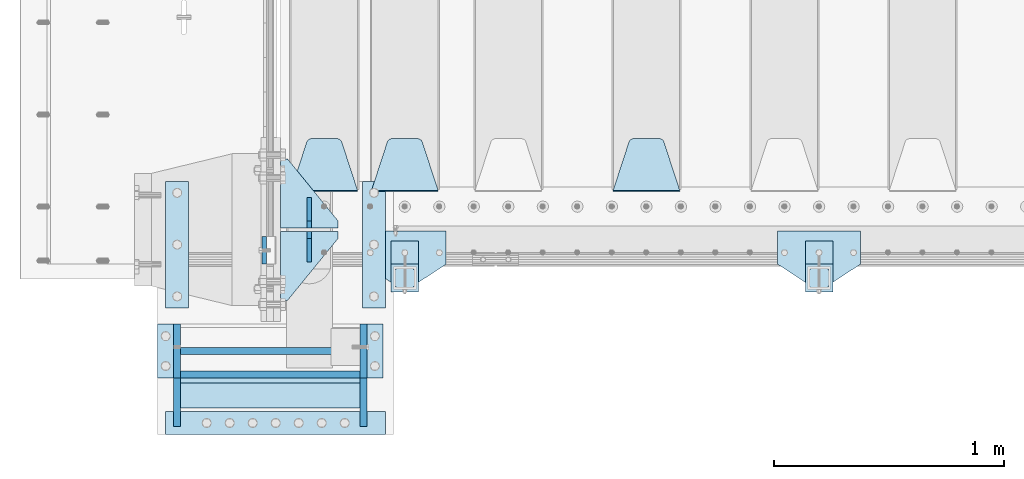
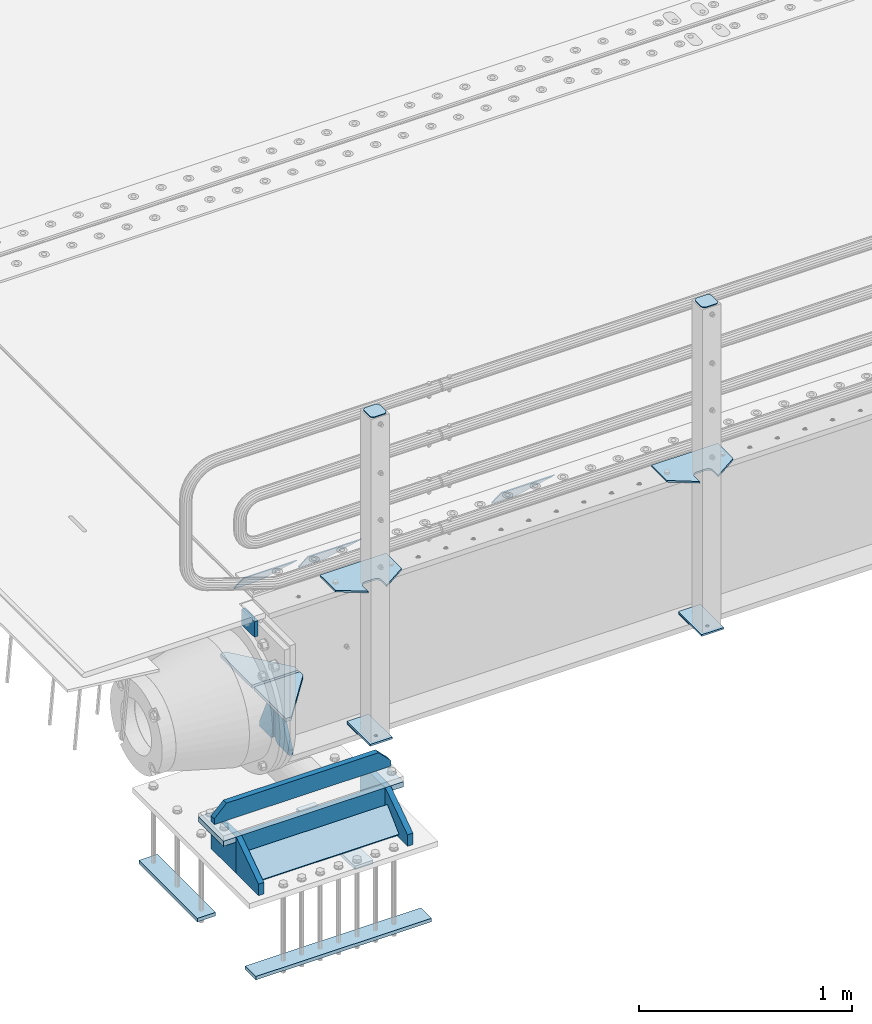
# One storey, part 174 of 219: 28 plates.
"""IFC2X3 building model written with IfcOpenShell, lengths in millimetres."""

from ifc_helpers import new_model, si_unit, frame, origin_with_axes, place, context, subcontext, project, spatial, faceted_brep, material, type_object, element, save


model = new_model("IFC2X3")

# Units and contexts
model_context = context("Model", 3, precision=1e-05, world=origin_with_axes())
body_context = subcontext(model_context, "Body", "Model", "MODEL_VIEW")
ifc_project = project(units=[si_unit("LENGTHUNIT", "METRE", prefix="MILLI"), si_unit("AREAUNIT", "SQUARE_METRE"), si_unit("VOLUMEUNIT", "CUBIC_METRE"), si_unit("MASSUNIT", "GRAM", prefix="KILO"), si_unit("TIMEUNIT", "SECOND"), si_unit("PLANEANGLEUNIT", "RADIAN"), si_unit("SOLIDANGLEUNIT", "STERADIAN"), si_unit("THERMODYNAMICTEMPERATUREUNIT", "DEGREE_CELSIUS"), si_unit("LUMINOUSINTENSITYUNIT", "LUMEN")], contexts=[model_context])

# Site, building, storey
site_placement = place(None, origin_with_axes())
site = spatial("IfcSite", under=ifc_project, at=site_placement, CompositionType="ELEMENT")
building_placement = place(site_placement, origin_with_axes())
building = spatial("IfcBuilding", under=site, at=building_placement, Name="Standard", CompositionType="ELEMENT")
storey_placement = place(building_placement, origin_with_axes())
storey = spatial("IfcBuildingStorey", under=building, at=storey_placement, Name="Undefined", CompositionType="ELEMENT", Elevation=0.0)

# Plates
ifc_material_1 = material(Name="STEEL/S355N")
plate_type_1 = type_object("IfcPlateType", PredefinedType="NOTDEFINED")
plate_1_placement = place(storey_placement, frame((-60.0000000001136, 23970.0004459814, -106.000105640918), z_axis=(0.0, -0.999999999987744, -4.95099999993769e-06), x_axis=(0.0, -4.95099997756316e-06, 0.999999999987744)))
element("IfcPlate", 1, at=plate_1_placement, inside=storey, type_object=plate_type_1, material=ifc_material_1, context=body_context, shape_type="Brep", body=[
    faceted_brep([(0.0, -10.0, 0.0), (4.30816271546064e-10, -10.0, 120.000000000004), (4.30816271546064e-10, 10.0, 120.000000000004), (0.0, 10.0, 0.0), (89.9999999999979, -10.0, 120.000000000004), (89.9999999999979, 10.0, 120.000000000004), (90.0, -10.0, 1.09139364212751e-11), (90.0, 10.0, 1.09139364212751e-11)], [[[0, 1, 2, 3]], [[1, 4, 5, 2]], [[4, 6, 7, 5]], [[6, 0, 3, 7]], [[5, 7, 3, 2]], [[6, 4, 1, 0]]]),
])
plate_type_2 = type_object("IfcPlateType", PredefinedType="NOTDEFINED")
plate_2_placement = place(storey_placement, frame((1745.0, 24168.232233047, -1.76776695296758), z_axis=(0.0, 0.707106781186547, -0.707106781186548), x_axis=(-1.0, 0.0, 0.0)))
element("IfcPlate", 2, at=plate_2_placement, inside=storey, type_object=plate_type_2, material=ifc_material_1, context=body_context, shape_type="Brep", body=[
    faceted_brep([(0.0, -2.5, 0.0), (69.345504679477, -2.5, 300.171731424834), (69.345504679477, 2.49999999999636, 300.171731424831), (0.0, 2.5, 0.0), (70.9274061199576, -2.50000000000364, 304.8974424154), (70.9274061199576, 2.49999999999636, 304.8974424154), (73.3818627772307, -2.50000000000364, 309.234538108532), (73.3818627772307, 2.49999999999636, 309.234538108532), (76.6187032999569, -2.50000000000364, 313.023683126106), (76.6187032999569, 2.49999999999636, 313.023683126106), (80.5190132704993, -2.50000000000364, 316.125672595372), (80.5190132704993, 2.49999999999636, 316.125672595372), (84.9395038596831, -2.50000000000364, 318.426546230476), (84.9395038596831, 2.5, 318.426546230479), (89.7177759439237, -2.50000000000364, 319.841774983277), (89.7177759439237, 2.5, 319.841774983281), (94.6782862926502, -2.50000000000364, 320.319366455078), (94.6782862926502, 2.49999999999636, 320.319366455078), (195.32171370735, -2.50000000000364, 320.319366455078), (195.32171370735, 2.49999999999636, 320.319366455078), (200.282224056076, -2.50000000000364, 319.841774983277), (200.282224056076, 2.5, 319.841774983281), (205.060496140317, -2.50000000000364, 318.426546230476), (205.060496140317, 2.49999999999636, 318.426546230476), (209.480986729501, -2.50000000000364, 316.125672595372), (209.480986729501, 2.49999999999636, 316.125672595372), (213.381296700043, -2.50000000000364, 313.023683126106), (213.381296700043, 2.49999999999272, 313.023683126106), (216.618137222769, -2.50000000000364, 309.234538108529), (216.618137222769, 2.49999999999636, 309.234538108525), (219.072593880042, -2.50000000000364, 304.8974424154), (219.072593880042, 2.49999999999636, 304.8974424154), (220.654495320523, -2.5, 300.171731424834), (220.654495320523, 2.49999999999636, 300.171731424831), (290.0, -2.50000000000364, 3.63797880709171e-12), (290.0, 2.49999999999636, 0.0)], [[[0, 1, 2, 3]], [[1, 4, 5, 2]], [[4, 6, 7, 5]], [[6, 8, 9, 7]], [[8, 10, 11, 9]], [[10, 12, 13, 11]], [[12, 14, 15, 13]], [[14, 16, 17, 15]], [[16, 18, 19, 17]], [[18, 20, 21, 19]], [[20, 22, 23, 21]], [[22, 24, 25, 23]], [[24, 26, 27, 25]], [[26, 28, 29, 27]], [[28, 30, 31, 29]], [[30, 32, 33, 31]], [[32, 34, 35, 33]], [[34, 0, 3, 35]], [[5, 7, 9, 11, 13, 15, 17, 19, 21, 23, 25, 27, 29, 31, 33, 35, 3, 2]], [[34, 32, 30, 28, 26, 24, 22, 20, 18, 16, 14, 12, 10, 8, 6, 4, 1, 0]]]),
])
plate_3_placement = place(storey_placement, frame((695.0, 24168.232233047, -1.76776695296758), z_axis=(0.0, 0.707106781186547, -0.707106781186548), x_axis=(-1.0, 0.0, 0.0)))
element("IfcPlate", 3, at=plate_3_placement, inside=storey, type_object=plate_type_2, material=ifc_material_1, context=body_context, shape_type="Brep", body=[
    faceted_brep([(0.0, -2.5, 0.0), (69.345504679477, -2.5, 300.171731424834), (69.345504679477, 2.49999999999636, 300.171731424831), (0.0, 2.5, 0.0), (70.9274061199576, -2.50000000000364, 304.8974424154), (70.9274061199576, 2.49999999999636, 304.8974424154), (73.3818627772307, -2.50000000000364, 309.234538108532), (73.3818627772307, 2.49999999999636, 309.234538108532), (76.6187032999569, -2.50000000000364, 313.023683126106), (76.6187032999569, 2.49999999999636, 313.023683126106), (80.5190132704993, -2.50000000000364, 316.125672595372), (80.5190132704993, 2.49999999999636, 316.125672595372), (84.9395038596831, -2.50000000000364, 318.426546230476), (84.9395038596831, 2.5, 318.426546230479), (89.7177759439237, -2.50000000000364, 319.841774983277), (89.7177759439237, 2.5, 319.841774983281), (94.6782862926502, -2.50000000000364, 320.319366455078), (94.6782862926502, 2.49999999999636, 320.319366455078), (195.32171370735, -2.50000000000364, 320.319366455078), (195.32171370735, 2.49999999999636, 320.319366455078), (200.282224056076, -2.50000000000364, 319.841774983277), (200.282224056076, 2.5, 319.841774983281), (205.060496140317, -2.50000000000364, 318.426546230476), (205.060496140317, 2.49999999999636, 318.426546230476), (209.480986729501, -2.50000000000364, 316.125672595372), (209.480986729501, 2.49999999999636, 316.125672595372), (213.381296700043, -2.50000000000364, 313.023683126106), (213.381296700043, 2.49999999999272, 313.023683126106), (216.618137222769, -2.50000000000364, 309.234538108529), (216.618137222769, 2.49999999999636, 309.234538108525), (219.072593880042, -2.50000000000364, 304.8974424154), (219.072593880042, 2.49999999999636, 304.8974424154), (220.654495320523, -2.5, 300.171731424834), (220.654495320523, 2.49999999999636, 300.171731424831), (290.0, -2.50000000000364, 3.63797880709171e-12), (290.0, 2.49999999999636, 0.0)], [[[0, 1, 2, 3]], [[1, 4, 5, 2]], [[4, 6, 7, 5]], [[6, 8, 9, 7]], [[8, 10, 11, 9]], [[10, 12, 13, 11]], [[12, 14, 15, 13]], [[14, 16, 17, 15]], [[16, 18, 19, 17]], [[18, 20, 21, 19]], [[20, 22, 23, 21]], [[22, 24, 25, 23]], [[24, 26, 27, 25]], [[26, 28, 29, 27]], [[28, 30, 31, 29]], [[30, 32, 33, 31]], [[32, 34, 35, 33]], [[34, 0, 3, 35]], [[5, 7, 9, 11, 13, 15, 17, 19, 21, 23, 25, 27, 29, 31, 33, 35, 3, 2]], [[34, 32, 30, 28, 26, 24, 22, 20, 18, 16, 14, 12, 10, 8, 6, 4, 1, 0]]]),
])
plate_4_placement = place(storey_placement, frame((345.0, 24168.232233047, -1.76776695296758), z_axis=(0.0, 0.707106781186547, -0.707106781186548), x_axis=(-1.0, 0.0, 0.0)))
element("IfcPlate", 4, at=plate_4_placement, inside=storey, type_object=plate_type_2, material=ifc_material_1, context=body_context, shape_type="Brep", body=[
    faceted_brep([(0.0, -2.5, 0.0), (69.345504679477, -2.5, 300.171731424834), (69.345504679477, 2.49999999999636, 300.171731424831), (0.0, 2.5, 0.0), (70.9274061199576, -2.50000000000364, 304.8974424154), (70.9274061199576, 2.49999999999636, 304.8974424154), (73.3818627772307, -2.50000000000364, 309.234538108532), (73.3818627772307, 2.49999999999636, 309.234538108532), (76.6187032999569, -2.50000000000364, 313.023683126106), (76.6187032999569, 2.49999999999636, 313.023683126106), (80.5190132704993, -2.50000000000364, 316.125672595372), (80.5190132704993, 2.49999999999636, 316.125672595372), (84.9395038596831, -2.50000000000364, 318.426546230476), (84.9395038596831, 2.5, 318.426546230479), (89.7177759439237, -2.50000000000364, 319.841774983277), (89.7177759439237, 2.5, 319.841774983281), (94.6782862926502, -2.50000000000364, 320.319366455078), (94.6782862926502, 2.49999999999636, 320.319366455078), (195.32171370735, -2.50000000000364, 320.319366455078), (195.32171370735, 2.49999999999636, 320.319366455078), (200.282224056076, -2.50000000000364, 319.841774983277), (200.282224056076, 2.5, 319.841774983281), (205.060496140317, -2.50000000000364, 318.426546230476), (205.060496140317, 2.49999999999636, 318.426546230476), (209.480986729501, -2.50000000000364, 316.125672595372), (209.480986729501, 2.49999999999636, 316.125672595372), (213.381296700043, -2.50000000000364, 313.023683126106), (213.381296700043, 2.49999999999272, 313.023683126106), (216.618137222769, -2.50000000000364, 309.234538108529), (216.618137222769, 2.49999999999636, 309.234538108525), (219.072593880042, -2.50000000000364, 304.8974424154), (219.072593880042, 2.49999999999636, 304.8974424154), (220.654495320523, -2.5, 300.171731424834), (220.654495320523, 2.49999999999636, 300.171731424831), (290.0, -2.50000000000364, 3.63797880709171e-12), (290.0, 2.49999999999636, 0.0)], [[[0, 1, 2, 3]], [[1, 4, 5, 2]], [[4, 6, 7, 5]], [[6, 8, 9, 7]], [[8, 10, 11, 9]], [[10, 12, 13, 11]], [[12, 14, 15, 13]], [[14, 16, 17, 15]], [[16, 18, 19, 17]], [[18, 20, 21, 19]], [[20, 22, 23, 21]], [[22, 24, 25, 23]], [[24, 26, 27, 25]], [[26, 28, 29, 27]], [[28, 30, 31, 29]], [[30, 32, 33, 31]], [[32, 34, 35, 33]], [[34, 0, 3, 35]], [[5, 7, 9, 11, 13, 15, 17, 19, 21, 23, 25, 27, 29, 31, 33, 35, 3, 2]], [[34, 32, 30, 28, 26, 24, 22, 20, 18, 16, 14, 12, 10, 8, 6, 4, 1, 0]]]),
])
plate_type_3 = type_object("IfcPlateType", PredefinedType="NOTDEFINED")
for number, where, z_axis, x_axis in (
    (5, (259.999999999996, 24008.0, -515.0), (0.0, 1.0, 0.0), (-1.0, 0.0, 0.0)),
    (6, (259.999999999996, 23992.0, -515.0), (0.0, -1.0, 0.0), (-1.0, 0.0, 0.0)),
):
    element("IfcPlate", number, at=place(storey_placement, frame(where, z_axis=z_axis, x_axis=x_axis)), inside=storey, type_object=plate_type_3, material=ifc_material_1, context=body_context, shape_type="Brep", body=[
        faceted_brep([(0.0, -10.0, 0.0), (0.0, -10.0, 30.0), (0.0, 10.0, 30.0), (0.0, 10.0, 0.0), (220.0, -10.0, 300.0), (220.0, 10.0, 300.0), (250.0, -10.0, 300.0), (250.0, 10.0, 300.0), (250.0, -10.0, 0.0), (250.0, 10.0, 0.0)], [[[0, 1, 2, 3]], [[1, 4, 5, 2]], [[4, 6, 7, 5]], [[6, 8, 9, 7]], [[8, 0, 3, 9]], [[5, 7, 9, 3, 2]], [[8, 6, 4, 1, 0]]]),
    ])
plate_type_4 = type_object("IfcPlateType", PredefinedType="NOTDEFINED")
for number, where, z_axis, x_axis in (
    (7, (135.0, 23860.0, -860.0), (0.0, 0.0, 1.0), (0.0, 1.0, 0.0)),
    (8, (135.0, 24140.0, -860.0), (0.0, 0.0, 1.0), (0.0, -1.0, 0.0)),
):
    element("IfcPlate", number, at=place(storey_placement, frame(where, z_axis=z_axis, x_axis=x_axis)), inside=storey, type_object=plate_type_4, material=ifc_material_1, context=body_context, shape_type="Brep", body=[
        faceted_brep([(0.0, -10.0, 0.0), (0.0, -10.0, 30.0), (0.0, 10.0, 30.0), (0.0, 10.0, 0.0), (102.0, -10.0, 250.0), (102.0, 10.0, 250.0), (132.0, -10.0, 250.0), (132.0, 10.0, 250.0), (132.0, -10.0, 30.0), (132.0, 10.0, 30.0), (131.544232590368, -10.0, 24.790554669992), (131.544232590368, 10.0, 24.790554669992), (130.190778623579, -10.0, 19.7393957002299), (130.190778623579, 10.0, 19.7393957002299), (127.980762113533, -10.0, 15.0), (127.980762113533, 10.0, 15.0), (124.98133329357, -10.0, 10.7163717094038), (124.98133329357, 10.0, 10.7163717094038), (121.283628290596, -10.0, 7.01866670643062), (121.283628290596, 10.0, 7.01866670643062), (117.0, -10.0, 4.01923788646684), (117.0, 10.0, 4.01923788646684), (112.260604299769, -10.0, 1.80922137642278), (112.260604299769, 10.0, 1.80922137642278), (107.209445330009, -10.0, 0.455767409633722), (107.209445330009, 10.0, 0.455767409633722), (102.0, -10.0, 0.0), (102.0, 10.0, 0.0)], [[[0, 1, 2, 3]], [[1, 4, 5, 2]], [[4, 6, 7, 5]], [[6, 8, 9, 7]], [[8, 10, 11, 9]], [[10, 12, 13, 11]], [[12, 14, 15, 13]], [[14, 16, 17, 15]], [[16, 18, 19, 17]], [[18, 20, 21, 19]], [[20, 22, 23, 21]], [[22, 24, 25, 23]], [[24, 26, 27, 25]], [[26, 0, 3, 27]], [[5, 7, 9, 11, 13, 15, 17, 19, 21, 23, 25, 27, 3, 2]], [[26, 24, 22, 20, 18, 16, 14, 12, 10, 8, 6, 4, 1, 0]]]),
    ])
ifc_material_2 = material(Name="STEEL/S355J2")
plate_type_5 = type_object("IfcPlateType", PredefinedType="NOTDEFINED")
plate_5_placement = place(storey_placement, frame((2530.0, 23995.0, 5.00000000004911), z_axis=(0.0, -1.0, 0.0), x_axis=(-1.0, 0.0, 0.0)))
element("IfcPlate", 9, at=plate_5_placement, inside=storey, type_object=plate_type_5, material=ifc_material_2, context=body_context, shape_type="Brep", body=[
    faceted_brep([(0.0, -5.0, 0.0), (2.31396552408114e-06, -5.0, 145.0), (2.31396552408114e-06, 5.0, 145.0), (0.0, 5.0, 0.0), (130.0, -5.0, 230.0), (130.0, 5.0, 230.0), (130.0, -5.0, 180.0), (130.0, 5.0, 180.0), (130.48036798992, -5.0, 175.122741949599), (130.48036798992, 5.0, 175.122741949599), (131.903011687218, -5.0, 170.432914190875), (131.903011687218, 5.0, 170.432914190875), (134.213259692437, -5.0, 166.110744174512), (134.213259692437, 5.0, 166.110744174512), (137.322330470337, -5.0, 162.322330470335), (137.322330470337, 5.0, 162.322330470335), (141.11074417451, -5.0, 159.213259692435), (141.11074417451, 5.0, 159.213259692435), (145.432914190873, -5.0, 156.903011687216), (145.432914190873, 5.0, 156.903011687216), (150.122741949597, -5.0, 155.48036798992), (150.122741949597, 5.0, 155.48036798992), (155.0, -5.0, 155.0), (155.0, 5.0, 155.0), (205.0, -5.0, 155.0), (205.0, 5.0, 155.0), (209.877258050403, -5.0, 155.48036798992), (209.877258050403, 5.0, 155.48036798992), (214.567085809127, -5.0, 156.903011687216), (214.567085809127, 5.0, 156.903011687216), (218.88925582549, -5.0, 159.213259692435), (218.88925582549, 5.0, 159.213259692435), (222.677669529663, -5.0, 162.322330470335), (222.677669529663, 5.0, 162.322330470335), (225.786740307563, -5.0, 166.110744174512), (225.786740307563, 5.0, 166.110744174512), (228.096988312782, -5.0, 170.432914190875), (228.096988312782, 5.0, 170.432914190875), (229.51963201008, -5.0, 175.122741949599), (229.51963201008, 5.0, 175.122741949599), (230.0, -5.0, 180.0), (230.0, 5.0, 180.0), (230.0, -5.0, 230.0), (230.0, 5.0, 230.0), (360.0, -5.0, 145.0), (360.0, 5.0, 145.0), (360.0, -5.0, -7.27595761418343e-12), (360.0, 5.0, -7.27595761418343e-12)], [[[0, 1, 2, 3]], [[1, 4, 5, 2]], [[4, 6, 7, 5]], [[6, 8, 9, 7]], [[8, 10, 11, 9]], [[10, 12, 13, 11]], [[12, 14, 15, 13]], [[14, 16, 17, 15]], [[16, 18, 19, 17]], [[18, 20, 21, 19]], [[20, 22, 23, 21]], [[22, 24, 25, 23]], [[24, 26, 27, 25]], [[26, 28, 29, 27]], [[28, 30, 31, 29]], [[30, 32, 33, 31]], [[32, 34, 35, 33]], [[34, 36, 37, 35]], [[36, 38, 39, 37]], [[38, 40, 41, 39]], [[40, 42, 43, 41]], [[42, 44, 45, 43]], [[44, 46, 47, 45]], [[46, 0, 3, 47]], [[5, 7, 9, 11, 13, 15, 17, 19, 21, 23, 25, 27, 29, 31, 33, 35, 37, 39, 41, 43, 45, 47, 3, 2]], [[46, 44, 42, 40, 38, 36, 34, 32, 30, 28, 26, 24, 22, 20, 18, 16, 14, 12, 10, 8, 6, 4, 1, 0]]]),
])
plate_6_placement = place(storey_placement, frame((730.0, 23995.0, 5.00000000004911), z_axis=(0.0, -1.0, 0.0), x_axis=(-1.0, 0.0, 0.0)))
element("IfcPlate", 10, at=plate_6_placement, inside=storey, type_object=plate_type_5, material=ifc_material_2, context=body_context, shape_type="Brep", body=[
    faceted_brep([(0.0, -5.0, 0.0), (2.31396552408114e-06, -5.0, 145.0), (2.31396552408114e-06, 5.0, 145.0), (0.0, 5.0, 0.0), (130.0, -5.0, 230.0), (130.0, 5.0, 230.0), (130.0, -5.0, 180.0), (130.0, 5.0, 180.0), (130.48036798992, -5.0, 175.122741949599), (130.48036798992, 5.0, 175.122741949599), (131.903011687218, -5.0, 170.432914190875), (131.903011687218, 5.0, 170.432914190875), (134.213259692437, -5.0, 166.110744174512), (134.213259692437, 5.0, 166.110744174512), (137.322330470337, -5.0, 162.322330470335), (137.322330470337, 5.0, 162.322330470335), (141.11074417451, -5.0, 159.213259692435), (141.11074417451, 5.0, 159.213259692435), (145.432914190873, -5.0, 156.903011687216), (145.432914190873, 5.0, 156.903011687216), (150.122741949597, -5.0, 155.48036798992), (150.122741949597, 5.0, 155.48036798992), (155.0, -5.0, 155.0), (155.0, 5.0, 155.0), (205.0, -5.0, 155.0), (205.0, 5.0, 155.0), (209.877258050403, -5.0, 155.48036798992), (209.877258050403, 5.0, 155.48036798992), (214.567085809127, -5.0, 156.903011687216), (214.567085809127, 5.0, 156.903011687216), (218.88925582549, -5.0, 159.213259692435), (218.88925582549, 5.0, 159.213259692435), (222.677669529663, -5.0, 162.322330470335), (222.677669529663, 5.0, 162.322330470335), (225.786740307563, -5.0, 166.110744174512), (225.786740307563, 5.0, 166.110744174512), (228.096988312782, -5.0, 170.432914190875), (228.096988312782, 5.0, 170.432914190875), (229.51963201008, -5.0, 175.122741949599), (229.51963201008, 5.0, 175.122741949599), (230.0, -5.0, 180.0), (230.0, 5.0, 180.0), (230.0, -5.0, 230.0), (230.0, 5.0, 230.0), (360.0, -5.0, 145.0), (360.0, 5.0, 145.0), (360.0, -5.0, -7.27595761418343e-12), (360.0, 5.0, -7.27595761418343e-12)], [[[0, 1, 2, 3]], [[1, 4, 5, 2]], [[4, 6, 7, 5]], [[6, 8, 9, 7]], [[8, 10, 11, 9]], [[10, 12, 13, 11]], [[12, 14, 15, 13]], [[14, 16, 17, 15]], [[16, 18, 19, 17]], [[18, 20, 21, 19]], [[20, 22, 23, 21]], [[22, 24, 25, 23]], [[24, 26, 27, 25]], [[26, 28, 29, 27]], [[28, 30, 31, 29]], [[30, 32, 33, 31]], [[32, 34, 35, 33]], [[34, 36, 37, 35]], [[36, 38, 39, 37]], [[38, 40, 41, 39]], [[40, 42, 43, 41]], [[42, 44, 45, 43]], [[44, 46, 47, 45]], [[46, 0, 3, 47]], [[5, 7, 9, 11, 13, 15, 17, 19, 21, 23, 25, 27, 29, 31, 33, 35, 37, 39, 41, 43, 45, 47, 3, 2]], [[46, 44, 42, 40, 38, 36, 34, 32, 30, 28, 26, 24, 22, 20, 18, 16, 14, 12, 10, 8, 6, 4, 1, 0]]]),
])
plate_type_6 = type_object("IfcPlateType", PredefinedType="NOTDEFINED")
for number, where, z_axis, x_axis in (
    (11, (2409.99999999986, 23949.9999999998, -850.000000000002), (0.0, -1.0, 0.0), (-1.0, 0.0, 0.0)),
    (12, (609.999999999862, 23949.9999999998, -850.000000000002), (0.0, -1.0, 0.0), (-1.0, 0.0, 0.0)),
):
    element("IfcPlate", number, at=place(storey_placement, frame(where, z_axis=z_axis, x_axis=x_axis)), inside=storey, type_object=plate_type_6, material=ifc_material_2, context=body_context, shape_type="Brep", body=[
        faceted_brep([(53.6360389691836, -5.0, 176.363961030467), (53.6360389691836, 5.0, 176.363961030467), (59.9999999998618, 5.0, 178.999999999789), (59.9999999998618, -5.0, 178.999999999789), (66.3639610305399, 5.0, 176.363961030467), (66.3639610305399, -5.0, 176.363961030467), (68.9999999998618, 5.0, 169.999999999789), (68.9999999998618, -5.0, 169.999999999789), (66.3639610305399, 5.0, 163.636038969111), (66.3639610305399, -5.0, 163.636038969111), (59.9999999998618, 5.0, 160.999999999789), (59.9999999998618, -5.0, 160.999999999789), (53.6360389691836, 5.0, 163.636038969111), (53.6360389691836, -5.0, 163.636038969111), (50.9999999998618, 5.0, 169.999999999789), (50.9999999998618, -5.0, 169.999999999789), (120.0, -5.0, 0.0), (120.0, -5.0, 220.0), (0.0, -5.0, 220.0), (0.0, -5.0, 0.0), (0.0, 5.0, 0.0), (120.0, 5.0, 0.0), (120.0, 5.0, 220.0), (0.0, 5.0, 220.0)], [[[0, 1, 2, 3]], [[3, 2, 4, 5]], [[5, 4, 6, 7]], [[7, 6, 8, 9]], [[9, 8, 10, 11]], [[11, 10, 12, 13]], [[13, 12, 14, 15]], [[15, 14, 1, 0]], [[16, 17, 18, 19], [11, 13, 15, 0, 3, 5, 7, 9]], [[16, 19, 20, 21]], [[17, 16, 21, 22]], [[18, 17, 22, 23]], [[19, 18, 23, 20]], [[22, 21, 20, 23], [2, 1, 14, 12, 10, 8, 6, 4]]]),
    ])
plate_type_7 = type_object("IfcPlateType", PredefinedType="NOTDEFINED")
plate_7_placement = place(storey_placement, frame((2305.99999999987, 23833.9999999998, 1012.50000000001), z_axis=(0.0, -1.0, 0.0), x_axis=(1.0, 0.0, 0.0)))
element("IfcPlate", 13, at=plate_7_placement, inside=storey, type_object=plate_type_7, material=ifc_material_2, context=body_context, shape_type="Brep", body=[
    faceted_brep([(0.0, -2.5, 19.0), (0.0, -2.5, 69.0), (0.0, 2.5, 69.0), (0.0, 2.5, 19.0), (0.476369668545885, -2.5, 73.2278977451715), (0.476369668545885, 2.5, 73.2278977451715), (1.88159150985484, -2.5, 77.2437910432345), (1.88159150985484, 2.5, 77.2437910432345), (4.14520183310742, -2.5, 80.8463062353185), (4.14520183310742, 2.5, 80.8463062353185), (7.15369376468334, -2.5, 83.8547981668889), (7.15369376468334, 2.5, 83.8547981668889), (10.7562089567673, -2.5, 86.118408490147), (10.7562089567673, 2.5, 86.118408490147), (14.7721022548303, -2.5, 87.5236303314523), (14.7721022548303, 2.5, 87.5236303314523), (19.0, -2.5, 88.0), (19.0, 2.5, 88.0), (69.0, -2.5, 88.0), (69.0, 2.5, 88.0), (73.2278977451697, -2.5, 87.5236303314523), (73.2278977451697, 2.5, 87.5236303314523), (77.2437910432327, -2.5, 86.118408490147), (77.2437910432327, 2.5, 86.118408490147), (80.8463062353167, -2.5, 83.8547981668889), (80.8463062353167, 2.5, 83.8547981668889), (83.8547981668926, -2.5, 80.8463062353185), (83.8547981668926, 2.5, 80.8463062353185), (86.1184084901452, -2.5, 77.2437910432345), (86.1184084901452, 2.5, 77.2437910432345), (87.5236303314541, -2.5, 73.2278977451715), (87.5236303314541, 2.5, 73.2278977451715), (88.0, -2.5, 69.0), (88.0, 2.5, 69.0), (88.0, -2.5, 19.0), (88.0, 2.5, 19.0), (87.5236303314541, -2.5, 14.7721022548285), (87.5236303314541, 2.5, 14.7721022548285), (86.1184084901452, -2.5, 10.7562089567655), (86.1184084901452, 2.5, 10.7562089567655), (83.8547981668926, -2.5, 7.15369376468152), (83.8547981668926, 2.5, 7.15369376468152), (80.8463062353167, -2.5, 4.14520183311106), (80.8463062353167, 2.5, 4.14520183311106), (77.2437910432345, -2.5, 1.88159150985302), (77.2437910432345, 2.5, 1.88159150985302), (73.2278977451697, -2.5, 0.476369668547704), (73.2278977451697, 2.5, 0.476369668547704), (69.0, -2.5, 0.0), (69.0, 2.5, 0.0), (19.0, -2.5, 0.0), (19.0, 2.5, 0.0), (14.7721022548303, -2.5, 0.476369668547704), (14.7721022548303, 2.5, 0.476369668547704), (10.7562089567673, -2.5, 1.88159150985302), (10.7562089567673, 2.5, 1.88159150985302), (7.15369376468334, -2.5, 4.14520183311106), (7.15369376468334, 2.5, 4.14520183311106), (4.14520183310742, -2.5, 7.15369376468152), (4.14520183310742, 2.5, 7.15369376468152), (1.88159150985484, -2.5, 10.7562089567655), (1.88159150985484, 2.5, 10.7562089567655), (0.476369668545885, -2.5, 14.7721022548285), (0.476369668545885, 2.5, 14.7721022548285)], [[[0, 1, 2, 3]], [[1, 4, 5, 2]], [[4, 6, 7, 5]], [[6, 8, 9, 7]], [[8, 10, 11, 9]], [[10, 12, 13, 11]], [[12, 14, 15, 13]], [[14, 16, 17, 15]], [[16, 18, 19, 17]], [[18, 20, 21, 19]], [[20, 22, 23, 21]], [[22, 24, 25, 23]], [[24, 26, 27, 25]], [[26, 28, 29, 27]], [[28, 30, 31, 29]], [[30, 32, 33, 31]], [[32, 34, 35, 33]], [[34, 36, 37, 35]], [[36, 38, 39, 37]], [[38, 40, 41, 39]], [[40, 42, 43, 41]], [[42, 44, 45, 43]], [[44, 46, 47, 45]], [[46, 48, 49, 47]], [[48, 50, 51, 49]], [[50, 52, 53, 51]], [[52, 54, 55, 53]], [[54, 56, 57, 55]], [[56, 58, 59, 57]], [[58, 60, 61, 59]], [[60, 62, 63, 61]], [[62, 0, 3, 63]], [[5, 7, 9, 11, 13, 15, 17, 19, 21, 23, 25, 27, 29, 31, 33, 35, 37, 39, 41, 43, 45, 47, 49, 51, 53, 55, 57, 59, 61, 63, 3, 2]], [[62, 60, 58, 56, 54, 52, 50, 48, 46, 44, 42, 40, 38, 36, 34, 32, 30, 28, 26, 24, 22, 20, 18, 16, 14, 12, 10, 8, 6, 4, 1, 0]]]),
])
plate_8_placement = place(storey_placement, frame((505.999999999869, 23833.9999999998, 1012.50000000001), z_axis=(0.0, -1.0, 0.0), x_axis=(1.0, 0.0, 0.0)))
element("IfcPlate", 14, at=plate_8_placement, inside=storey, type_object=plate_type_7, material=ifc_material_2, context=body_context, shape_type="Brep", body=[
    faceted_brep([(0.0, -2.5, 19.0), (0.0, -2.5, 69.0), (0.0, 2.5, 69.0), (0.0, 2.5, 19.0), (0.476369668545885, -2.5, 73.2278977451715), (0.476369668545885, 2.5, 73.2278977451715), (1.88159150985484, -2.5, 77.2437910432345), (1.88159150985484, 2.5, 77.2437910432345), (4.14520183310742, -2.5, 80.8463062353185), (4.14520183310742, 2.5, 80.8463062353185), (7.15369376468334, -2.5, 83.8547981668889), (7.15369376468334, 2.5, 83.8547981668889), (10.7562089567673, -2.5, 86.118408490147), (10.7562089567673, 2.5, 86.118408490147), (14.7721022548303, -2.5, 87.5236303314523), (14.7721022548303, 2.5, 87.5236303314523), (19.0, -2.5, 88.0), (19.0, 2.5, 88.0), (69.0, -2.5, 88.0), (69.0, 2.5, 88.0), (73.2278977451697, -2.5, 87.5236303314523), (73.2278977451697, 2.5, 87.5236303314523), (77.2437910432327, -2.5, 86.118408490147), (77.2437910432327, 2.5, 86.118408490147), (80.8463062353167, -2.5, 83.8547981668889), (80.8463062353167, 2.5, 83.8547981668889), (83.8547981668926, -2.5, 80.8463062353185), (83.8547981668926, 2.5, 80.8463062353185), (86.1184084901452, -2.5, 77.2437910432345), (86.1184084901452, 2.5, 77.2437910432345), (87.5236303314541, -2.5, 73.2278977451715), (87.5236303314541, 2.5, 73.2278977451715), (88.0, -2.5, 69.0), (88.0, 2.5, 69.0), (88.0, -2.5, 19.0), (88.0, 2.5, 19.0), (87.5236303314541, -2.5, 14.7721022548285), (87.5236303314541, 2.5, 14.7721022548285), (86.1184084901452, -2.5, 10.7562089567655), (86.1184084901452, 2.5, 10.7562089567655), (83.8547981668926, -2.5, 7.15369376468152), (83.8547981668926, 2.5, 7.15369376468152), (80.8463062353167, -2.5, 4.14520183311106), (80.8463062353167, 2.5, 4.14520183311106), (77.2437910432345, -2.5, 1.88159150985302), (77.2437910432345, 2.5, 1.88159150985302), (73.2278977451697, -2.5, 0.476369668547704), (73.2278977451697, 2.5, 0.476369668547704), (69.0, -2.5, 0.0), (69.0, 2.5, 0.0), (19.0, -2.5, 0.0), (19.0, 2.5, 0.0), (14.7721022548303, -2.5, 0.476369668547704), (14.7721022548303, 2.5, 0.476369668547704), (10.7562089567673, -2.5, 1.88159150985302), (10.7562089567673, 2.5, 1.88159150985302), (7.15369376468334, -2.5, 4.14520183311106), (7.15369376468334, 2.5, 4.14520183311106), (4.14520183310742, -2.5, 7.15369376468152), (4.14520183310742, 2.5, 7.15369376468152), (1.88159150985484, -2.5, 10.7562089567655), (1.88159150985484, 2.5, 10.7562089567655), (0.476369668545885, -2.5, 14.7721022548285), (0.476369668545885, 2.5, 14.7721022548285)], [[[0, 1, 2, 3]], [[1, 4, 5, 2]], [[4, 6, 7, 5]], [[6, 8, 9, 7]], [[8, 10, 11, 9]], [[10, 12, 13, 11]], [[12, 14, 15, 13]], [[14, 16, 17, 15]], [[16, 18, 19, 17]], [[18, 20, 21, 19]], [[20, 22, 23, 21]], [[22, 24, 25, 23]], [[24, 26, 27, 25]], [[26, 28, 29, 27]], [[28, 30, 31, 29]], [[30, 32, 33, 31]], [[32, 34, 35, 33]], [[34, 36, 37, 35]], [[36, 38, 39, 37]], [[38, 40, 41, 39]], [[40, 42, 43, 41]], [[42, 44, 45, 43]], [[44, 46, 47, 45]], [[46, 48, 49, 47]], [[48, 50, 51, 49]], [[50, 52, 53, 51]], [[52, 54, 55, 53]], [[54, 56, 57, 55]], [[56, 58, 59, 57]], [[58, 60, 61, 59]], [[60, 62, 63, 61]], [[62, 0, 3, 63]], [[5, 7, 9, 11, 13, 15, 17, 19, 21, 23, 25, 27, 29, 31, 33, 35, 37, 39, 41, 43, 45, 47, 49, 51, 53, 55, 57, 59, 61, 63, 3, 2]], [[62, 60, 58, 56, 54, 52, 50, 48, 46, 44, 42, 40, 38, 36, 34, 32, 30, 28, 26, 24, 22, 20, 18, 16, 14, 12, 10, 8, 6, 4, 1, 0]]]),
])
plate_type_8 = type_object("IfcPlateType", PredefinedType="NOTDEFINED")
for number, where, z_axis, x_axis in (
    (15, (2409.99999999986, 23949.9999999998, -857.500000000002), (0.0, -1.0, 0.0), (-1.0, 0.0, 0.0)),
    (16, (609.999999999862, 23949.9999999998, -857.500000000002), (0.0, -1.0, 0.0), (-1.0, 0.0, 0.0)),
):
    element("IfcPlate", number, at=place(storey_placement, frame(where, z_axis=z_axis, x_axis=x_axis)), inside=storey, type_object=plate_type_8, material=ifc_material_2, context=body_context, shape_type="Brep", body=[
        faceted_brep([(0.0, -2.5, 0.0), (0.0, -2.5, 100.0), (0.0, 2.5, 100.0), (0.0, 2.5, 0.0), (120.0, -2.5, 100.0), (120.0, 2.5, 100.0), (120.0, -2.5, 0.0), (120.0, 2.5, 0.0)], [[[0, 1, 2, 3]], [[1, 4, 5, 2]], [[4, 6, 7, 5]], [[6, 0, 3, 7]], [[5, 7, 3, 2]], [[6, 4, 1, 0]]]),
    ])
plate_type_9 = type_object("IfcPlateType", PredefinedType="NOTDEFINED")
plate_9_placement = place(storey_placement, frame((355.000000000013, 23234.6428652468, -1017.14966545662), z_axis=(-1.0, 0.0, 0.0), x_axis=(0.0, 0.723355636225731, 0.690475650215464)))
element("IfcPlate", 17, at=plate_9_placement, inside=storey, type_object=plate_type_9, material=ifc_material_1, context=body_context, shape_type="Brep", body=[
    faceted_brep([(0.0, -15.0, 0.0), (0.0, -15.0000000000036, 779.0), (-3.63797880709171e-12, 15.0000000000036, 779.0), (0.0, 15.0, 0.0), (152.069061279293, -14.9999999999964, 779.0), (152.069061279297, 15.0, 779.0), (152.069061279293, -14.9999999999964, 0.0), (152.069061279297, 15.0, 0.0)], [[[0, 1, 2, 3]], [[1, 4, 5, 2]], [[4, 6, 7, 5]], [[6, 0, 3, 7]], [[5, 7, 3, 2]], [[6, 4, 1, 0]]]),
])
plate_type_10 = type_object("IfcPlateType", PredefinedType="NOTDEFINED")
for number, where, z_axis, x_axis in (
    (18, (366.000000000013, 23660.0000014662, -1468.0), (0.0, 1.0, 0.0), (1.0, 0.0, 0.0)),
    (19, (-488.999999999987, 23660.0000014662, -1468.0), (0.0, 1.0, 0.0), (1.0, 0.0, 0.0)),
):
    element("IfcPlate", number, at=place(storey_placement, frame(where, z_axis=z_axis, x_axis=x_axis)), inside=storey, type_object=plate_type_10, material=ifc_material_1, context=body_context, shape_type="Brep", body=[
        faceted_brep([(0.0, -10.0, 0.0), (1.00943179859314e-06, -10.0, 550.0), (1.00943179859314e-06, 10.0, 550.0), (0.0, 10.0, 0.0), (100.0, -10.0, 550.0), (100.0, 10.0, 550.0), (100.0, -10.0, 0.0), (100.0, 10.0, 0.0)], [[[0, 1, 2, 3]], [[1, 4, 5, 2]], [[4, 6, 7, 5]], [[6, 0, 3, 7]], [[5, 7, 3, 2]], [[6, 4, 1, 0]]]),
    ])
plate_10_placement = place(storey_placement, frame((-488.999999999987, 23110.0000014662, -1468.0), z_axis=(0.0, 1.0, 0.0), x_axis=(1.0, 0.0, 0.0)))
element("IfcPlate", 20, at=plate_10_placement, inside=storey, type_object=plate_type_10, material=ifc_material_1, context=body_context, shape_type="Brep", body=[
    faceted_brep([(0.0, -10.0, 0.0), (0.0, -10.0, 100.0), (0.0, 10.0, 100.0), (0.0, 10.0, 0.0), (955.0, -10.0, 100.0), (955.0, 10.0, 100.0), (955.0, -10.0, 0.0), (955.0, 10.0, 0.0)], [[[0, 1, 2, 3]], [[1, 4, 5, 2]], [[4, 6, 7, 5]], [[6, 0, 3, 7]], [[5, 7, 3, 2]], [[6, 4, 1, 0]]]),
])
plate_type_11 = type_object("IfcPlateType", PredefinedType="NOTDEFINED")
plate_11_placement = place(storey_placement, frame((370.000000000015, 23590.0, -818.000000000005), z_axis=(0.0, 0.0, -1.0), x_axis=(0.0, -1.0, 0.0)))
element("IfcPlate", 21, at=plate_11_placement, inside=storey, type_object=plate_type_11, material=ifc_material_1, context=body_context, shape_type="Brep", body=[
    faceted_brep([(0.0, -15.0, 0.0), (0.0, -15.0, 210.0), (0.0, 15.0, 210.0), (0.0, 15.0, 0.0), (235.0, -15.0, 210.0), (235.0, 15.0, 210.0), (235.0, -15.0, 0.0), (235.0, 15.0, 0.0)], [[[0, 1, 2, 3]], [[1, 4, 5, 2]], [[4, 6, 7, 5]], [[6, 0, 3, 7]], [[5, 7, 3, 2]], [[6, 4, 1, 0]]]),
])
for number, where, z_axis, x_axis in (
    (22, (370.000000000013, 23145.0, -1028.0), (0.0, 0.0, 1.0), (0.0, 1.0, 0.0)),
    (23, (-438.999999999987, 23145.0, -1028.0), (0.0, 0.0, 1.0), (0.0, 1.0, 0.0)),
):
    element("IfcPlate", number, at=place(storey_placement, frame(where, z_axis=z_axis, x_axis=x_axis)), inside=storey, type_object=plate_type_11, material=ifc_material_1, context=body_context, shape_type="Brep", body=[
        faceted_brep([(0.0, -15.0, 0.0), (0.0, -15.0, 66.0), (0.0, 15.0, 66.0), (0.0, 15.0, 0.0), (210.0, -15.0, 210.0), (210.0, 15.0, 210.0), (210.0, -15.0, 0.0), (210.0, 15.0, 0.0)], [[[0, 1, 2, 3]], [[1, 4, 5, 2]], [[4, 6, 7, 5]], [[6, 0, 3, 7]], [[5, 7, 3, 2]], [[6, 4, 1, 0]]]),
    ])
plate_12_placement = place(storey_placement, frame((-423.999999999987, 23370.0, -1028.0), z_axis=(1.0, 0.0, 0.0), x_axis=(0.0, 0.0, 1.0)))
element("IfcPlate", 24, at=plate_12_placement, inside=storey, type_object=plate_type_11, material=ifc_material_1, context=body_context, shape_type="Brep", body=[
    faceted_brep([(0.0, -15.0, 0.0), (0.0, -15.0000000000036, 779.0), (-3.63797880709171e-12, 15.0000000000036, 779.0), (0.0, 15.0, 0.0), (210.0, -15.0, 779.0), (210.0, 15.0, 779.0), (210.0, -15.0, 0.0), (210.0, 15.0, 0.0)], [[[0, 1, 2, 3]], [[1, 4, 5, 2]], [[4, 6, 7, 5]], [[6, 0, 3, 7]], [[5, 7, 3, 2]], [[6, 4, 1, 0]]]),
])
plate_13_placement = place(storey_placement, frame((-438.999999999987, 23590.0, -818.000000000004), z_axis=(0.0, 0.0, -1.0), x_axis=(0.0, -1.0, 0.0)))
element("IfcPlate", 25, at=plate_13_placement, inside=storey, type_object=plate_type_11, material=ifc_material_1, context=body_context, shape_type="Brep", body=[
    faceted_brep([(0.0, -15.0, 0.0), (0.0, -15.0, 210.0), (0.0, 15.0, 210.0), (0.0, 15.0, 0.0), (235.0, -15.0, 210.0), (235.0, 15.0, 210.0), (235.0, -15.0, 0.0), (235.0, 15.0, 0.0)], [[[0, 1, 2, 3]], [[1, 4, 5, 2]], [[4, 6, 7, 5]], [[6, 0, 3, 7]], [[5, 7, 3, 2]], [[6, 4, 1, 0]]]),
])
plate_type_12 = type_object("IfcPlateType", PredefinedType="NOTDEFINED")
plate_14_placement = place(storey_placement, frame((-513.999999999987, 23472.5, -788.000000000004), z_axis=(0.0, 0.0, 1.0), x_axis=(1.0, 0.0, 0.0)))
element("IfcPlate", 26, at=plate_14_placement, inside=storey, type_object=plate_type_12, material=ifc_material_1, context=body_context, shape_type="Brep", body=[
    faceted_brep([(0.0, -15.0, 0.0), (0.0, -15.0, 33.0), (0.0, 15.0, 33.0), (0.0, 15.0, 0.0), (67.0, -15.0, 100.0), (67.0, 15.0, 100.0), (892.0, -15.0, 100.0), (892.0, 15.0, 100.0), (959.0, -15.0, 33.0), (959.0, 15.0, 33.0), (959.0, -15.0, 0.0), (959.0, 15.0, 0.0)], [[[0, 1, 2, 3]], [[1, 4, 5, 2]], [[4, 6, 7, 5]], [[6, 8, 9, 7]], [[8, 10, 11, 9]], [[10, 0, 3, 11]], [[5, 7, 9, 11, 3, 2]], [[10, 8, 6, 4, 1, 0]]]),
])
plate_type_13 = type_object("IfcPlateType", PredefinedType="NOTDEFINED")
for number, where, z_axis, x_axis in (
    (27, (385.000000000013, 23355.0, -833.000000000004), (1.0, 0.0, 0.0), (0.0, 1.0, 0.0)),
    (28, (-523.999999999987, 23355.0, -833.000000000004), (1.0, 0.0, 0.0), (0.0, 1.0, 0.0)),
):
    element("IfcPlate", number, at=place(storey_placement, frame(where, z_axis=z_axis, x_axis=x_axis)), inside=storey, type_object=plate_type_13, material=ifc_material_1, context=body_context, shape_type="Brep", body=[
        faceted_brep([(0.0, -15.0, 0.0), (0.0, -15.0, 70.0), (0.0, 15.0, 70.0), (0.0, 15.0, 0.0), (235.0, -15.0, 70.0), (235.0, 15.0, 70.0), (235.0, -15.0, 0.0), (235.0, 15.0, 0.0)], [[[0, 1, 2, 3]], [[1, 4, 5, 2]], [[4, 6, 7, 5]], [[6, 0, 3, 7]], [[5, 7, 3, 2]], [[6, 4, 1, 0]]]),
    ])

save(model, "model.ifc")
